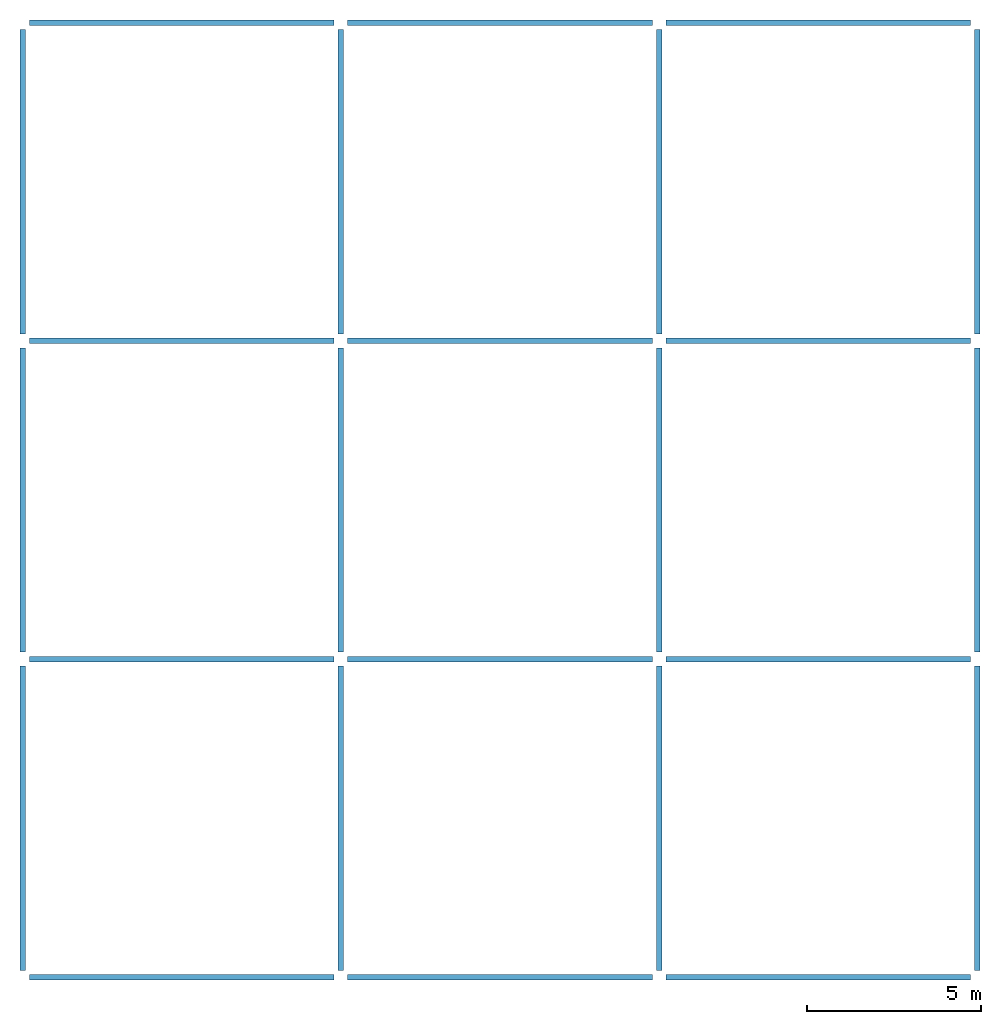
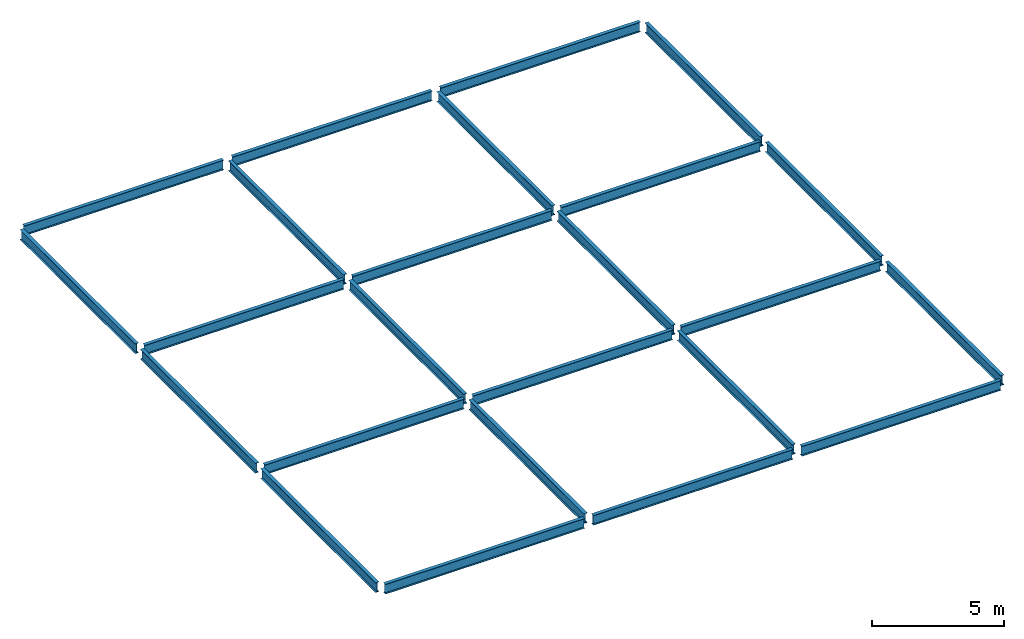
# One storey: 24 beams.
"""IFC2X3 building model written with IfcOpenShell, lengths in inches."""

from ifc_helpers import new_model, entity, si_unit, converted_unit, derived_unit, frame, origin_with_axes, origin_2d_with_axis, place, context, project, spatial, i_section, transform_2d, derived_profile, extrude, material, element, save


model = new_model("IFC2X3")

# Units and contexts
model_context = context("Model", 3, world=origin_with_axes())
ifc_project = project(units=[converted_unit("LENGTHUNIT", "INCH", entity("IfcLengthMeasure", 25.4), si_unit("LENGTHUNIT", "METRE", prefix="MILLI"), dimensions=[1, 0, 0, 0, 0, 0, 0]), converted_unit("AREAUNIT", "SQUARE INCH", entity("IfcAreaMeasure", 645.16), si_unit("AREAUNIT", "SQUARE_METRE", prefix="MICRO"), dimensions=[2, 0, 0, 0, 0, 0, 0]), converted_unit("VOLUMEUNIT", "CUBIC INCH", entity("IfcVolumeMeasure", 16387.064), si_unit("VOLUMEUNIT", "CUBIC_METRE", prefix="NANO"), dimensions=[3, 0, 0, 0, 0, 0, 0]), derived_unit("SECTIONMODULUSUNIT", [(converted_unit("LENGTHUNIT", "INCH", entity("IfcLengthMeasure", 25.4), si_unit("LENGTHUNIT", "METRE", prefix="MILLI"), dimensions=[1, 0, 0, 0, 0, 0, 0]), 3)]), derived_unit("MOMENTOFINERTIAUNIT", [(converted_unit("LENGTHUNIT", "INCH", entity("IfcLengthMeasure", 25.4), si_unit("LENGTHUNIT", "METRE", prefix="MILLI"), dimensions=[1, 0, 0, 0, 0, 0, 0]), 4)]), si_unit("PLANEANGLEUNIT", "RADIAN"), si_unit("TIMEUNIT", "SECOND"), converted_unit("FORCEUNIT", "LBF", entity("IfcForceMeasure", 4.448222), si_unit("FORCEUNIT", "NEWTON"), dimensions=[1, 1, -2, 0, 0, 0, 0]), derived_unit("TORQUEUNIT", [(converted_unit("LENGTHUNIT", "INCH", entity("IfcLengthMeasure", 25.4), si_unit("LENGTHUNIT", "METRE", prefix="MILLI"), dimensions=[1, 0, 0, 0, 0, 0, 0]), 1), (converted_unit("FORCEUNIT", "LBF", entity("IfcForceMeasure", 4.448222), si_unit("FORCEUNIT", "NEWTON"), dimensions=[1, 1, -2, 0, 0, 0, 0]), 1)]), converted_unit("PRESSUREUNIT", "PSI", entity("IfcPressureMeasure", 6894.7579), si_unit("PRESSUREUNIT", "PASCAL"), dimensions=[-1, 1, -2, 0, 0, 0, 0]), derived_unit("LINEARFORCEUNIT", [(converted_unit("LENGTHUNIT", "INCH", entity("IfcLengthMeasure", 25.4), si_unit("LENGTHUNIT", "METRE", prefix="MILLI"), dimensions=[1, 0, 0, 0, 0, 0, 0]), -1), (converted_unit("FORCEUNIT", "LBF", entity("IfcForceMeasure", 4.448222), si_unit("FORCEUNIT", "NEWTON"), dimensions=[1, 1, -2, 0, 0, 0, 0]), 1)]), derived_unit("PLANARFORCEUNIT", [(converted_unit("LENGTHUNIT", "INCH", entity("IfcLengthMeasure", 25.4), si_unit("LENGTHUNIT", "METRE", prefix="MILLI"), dimensions=[1, 0, 0, 0, 0, 0, 0]), -2), (converted_unit("FORCEUNIT", "LBF", entity("IfcForceMeasure", 4.448222), si_unit("FORCEUNIT", "NEWTON"), dimensions=[1, 1, -2, 0, 0, 0, 0]), 1)]), derived_unit("LINEARMOMENTUNIT", [(converted_unit("FORCEUNIT", "LBF", entity("IfcForceMeasure", 4.448222), si_unit("FORCEUNIT", "NEWTON"), dimensions=[1, 1, -2, 0, 0, 0, 0]), 1), (converted_unit("LENGTHUNIT", "INCH", entity("IfcLengthMeasure", 25.4), si_unit("LENGTHUNIT", "METRE", prefix="MILLI"), dimensions=[1, 0, 0, 0, 0, 0, 0]), 1), (converted_unit("LENGTHUNIT", "INCH", entity("IfcLengthMeasure", 25.4), si_unit("LENGTHUNIT", "METRE", prefix="MILLI"), dimensions=[1, 0, 0, 0, 0, 0, 0]), -1)]), derived_unit("SHEARMODULUSUNIT", [(converted_unit("LENGTHUNIT", "INCH", entity("IfcLengthMeasure", 25.4), si_unit("LENGTHUNIT", "METRE", prefix="MILLI"), dimensions=[1, 0, 0, 0, 0, 0, 0]), -2), (converted_unit("FORCEUNIT", "LBF", entity("IfcForceMeasure", 4.448222), si_unit("FORCEUNIT", "NEWTON"), dimensions=[1, 1, -2, 0, 0, 0, 0]), 1)]), derived_unit("MODULUSOFELASTICITYUNIT", [(converted_unit("LENGTHUNIT", "INCH", entity("IfcLengthMeasure", 25.4), si_unit("LENGTHUNIT", "METRE", prefix="MILLI"), dimensions=[1, 0, 0, 0, 0, 0, 0]), -2), (converted_unit("FORCEUNIT", "LBF", entity("IfcForceMeasure", 4.448222), si_unit("FORCEUNIT", "NEWTON"), dimensions=[1, 1, -2, 0, 0, 0, 0]), 1)]), converted_unit("THERMODYNAMICTEMPERATUREUNIT", "FAHRENHEIT", entity("IfcThermodynamicTemperatureMeasure", 0.55555556), si_unit("THERMODYNAMICTEMPERATUREUNIT", "KELVIN"), dimensions=[0, 0, 0, 0, 1, 0, 0]), derived_unit("THERMALEXPANSIONCOEFFICIENTUNIT", [(converted_unit("THERMODYNAMICTEMPERATUREUNIT", "FAHRENHEIT", entity("IfcThermodynamicTemperatureMeasure", 0.55555556), si_unit("THERMODYNAMICTEMPERATUREUNIT", "KELVIN"), dimensions=[0, 0, 0, 0, 1, 0, 0]), -1)])], contexts=[model_context])

# Site, building, storey
site = spatial("IfcSite", under=ifc_project, CompositionType="ELEMENT")
building = spatial("IfcBuilding", under=site, Name="Default Building", CompositionType="ELEMENT")
storey = spatial("IfcBuildingStorey", under=building, Name="TOP LEVEL", CompositionType="ELEMENT", Elevation=528.0)

# Beams
ifc_material = material(Name="A992Fy50")
for number, where, z_axis, x_axis, name in (
    (1, (0.0, 7.85, 528.0), (0.0, 1.0, 0.0), (-1.0, 0.0, 0.0), "49"),
    (2, (0.0, 367.85, 528.0), (0.0, 1.0, 0.0), (-1.0, 0.0, 0.0), "50"),
    (3, (0.0, 727.85, 528.0), (0.0, 1.0, 0.0), (-1.0, 0.0, 0.0), "51"),
    (4, (360.0, 7.85, 528.0), (0.0, 1.0, 0.0), (-1.0, 0.0, 0.0), "52"),
    (5, (360.0, 367.85, 528.0), (0.0, 1.0, 0.0), (-1.0, 0.0, 0.0), "53"),
    (6, (360.0, 727.85, 528.0), (0.0, 1.0, 0.0), (-1.0, 0.0, 0.0), "54"),
    (7, (720.0, 7.85, 528.0), (0.0, 1.0, 0.0), (-1.0, 0.0, 0.0), "55"),
    (8, (720.0, 367.85, 528.0), (0.0, 1.0, 0.0), (-1.0, 0.0, 0.0), "56"),
    (9, (720.0, 727.85, 528.0), (0.0, 1.0, 0.0), (-1.0, 0.0, 0.0), "57"),
    (10, (1080.0, 7.85, 528.0), (0.0, 1.0, 0.0), (-1.0, 0.0, 0.0), "58"),
    (11, (1080.0, 367.85, 528.0), (0.0, 1.0, 0.0), (-1.0, 0.0, 0.0), "59"),
    (12, (1080.0, 727.85, 528.0), (0.0, 1.0, 0.0), (-1.0, 0.0, 0.0), "60"),
):
    element("IfcBeam", number, at=place(None, frame(where, z_axis=z_axis, x_axis=x_axis)), inside=storey, material=ifc_material, Name=name, context=model_context, shape_type="SweptSolid", body=[
        extrude(derived_profile(i_section(OverallWidth=6.06, OverallDepth=18.1, WebThickness=0.36, FlangeThickness=0.605, at=origin_2d_with_axis()), transform_2d((0.0, -9.0500002))), origin_with_axes(), (0.0, 0.0, 1.0), 344.3),
    ])
for number, where, z_axis, x_axis, name in (
    (13, (7.75, 0.0, 528.0), (1.0, 0.0, 0.0), (0.0, 1.0, 0.0), "61"),
    (14, (367.75, 0.0, 528.0), (1.0, 0.0, 0.0), (0.0, 1.0, 0.0), "62"),
    (15, (727.75, 0.0, 528.0), (1.0, 0.0, 0.0), (0.0, 1.0, 0.0), "63"),
    (16, (7.75, 360.0, 528.0), (1.0, 0.0, 0.0), (0.0, 1.0, 0.0), "64"),
    (17, (367.75, 360.0, 528.0), (1.0, 0.0, 0.0), (0.0, 1.0, 0.0), "65"),
    (18, (727.75, 360.0, 528.0), (1.0, 0.0, 0.0), (0.0, 1.0, 0.0), "66"),
    (19, (7.75, 720.0, 528.0), (1.0, 0.0, 0.0), (0.0, 1.0, 0.0), "67"),
    (20, (367.75, 720.0, 528.0), (1.0, 0.0, 0.0), (0.0, 1.0, 0.0), "68"),
    (21, (727.75, 720.0, 528.0), (1.0, 0.0, 0.0), (0.0, 1.0, 0.0), "69"),
    (22, (7.75, 1080.0, 528.0), (1.0, 0.0, 0.0), (0.0, 1.0, 0.0), "70"),
    (23, (367.75, 1080.0, 528.0), (1.0, 0.0, 0.0), (0.0, 1.0, 0.0), "71"),
    (24, (727.75, 1080.0, 528.0), (1.0, 0.0, 0.0), (0.0, 1.0, 0.0), "72"),
):
    element("IfcBeam", number, at=place(None, frame(where, z_axis=z_axis, x_axis=x_axis)), inside=storey, material=ifc_material, Name=name, context=model_context, shape_type="SweptSolid", body=[
        extrude(derived_profile(i_section(OverallWidth=6.06, OverallDepth=18.1, WebThickness=0.36, FlangeThickness=0.605, at=origin_2d_with_axis()), transform_2d((0.0, -9.0500002))), origin_with_axes(), (0.0, 0.0, 1.0), 344.5),
    ])

save(model, "model.ifc")
